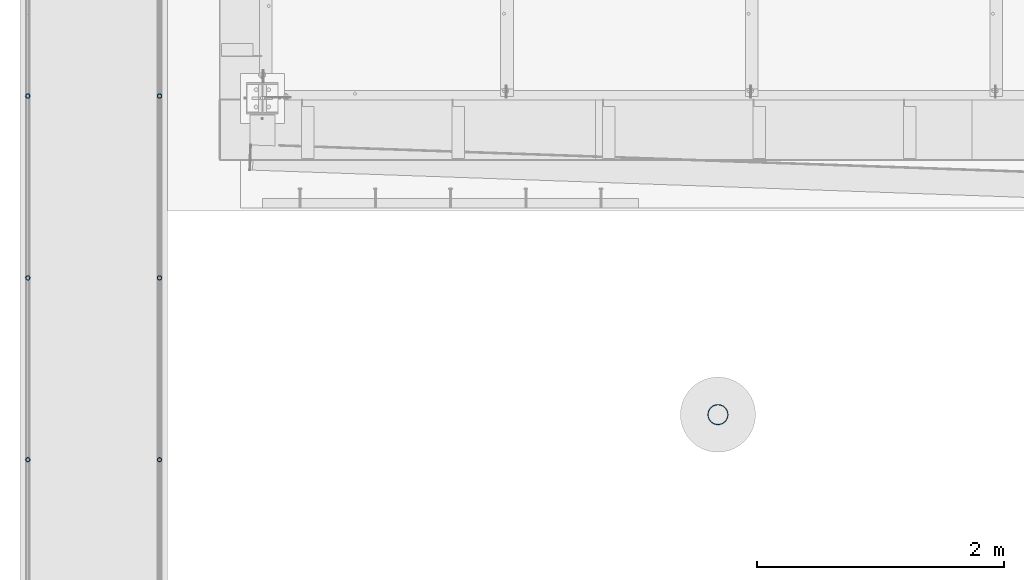
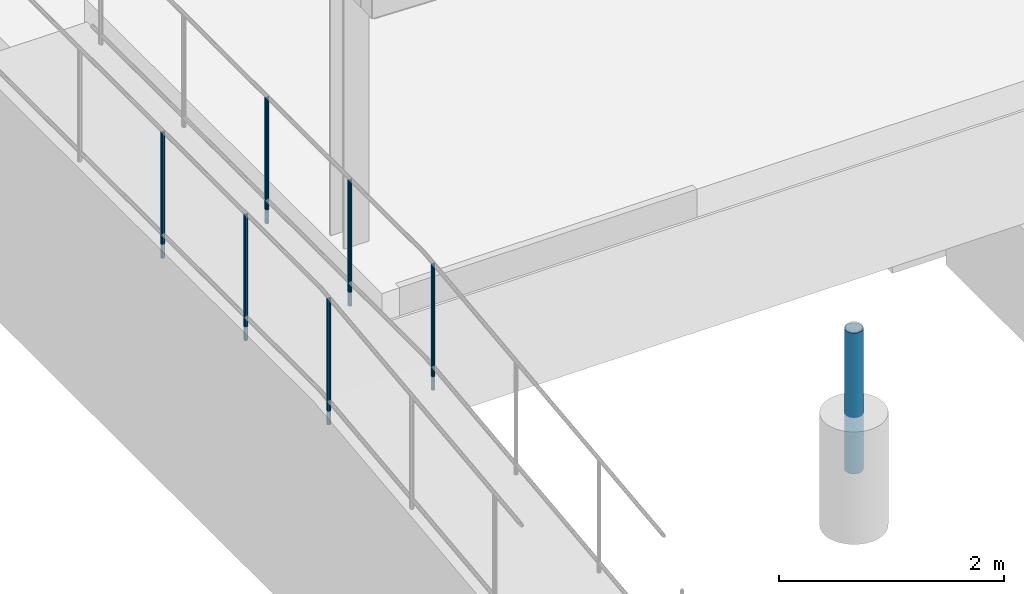
# One storey, part 884 of 1763: 7 columns, 3 elements without a shape of their own.
"""IFC2X3 building model written with IfcOpenShell, lengths in millimetres."""

import ifcopenshell
import ifcopenshell.guid

model = None  # the IFC model being written
_history = None  # IfcOwnerHistory: only IFC2X3 demands one
_inside = {}  # id of a spatial element -> (the spatial element, [elements in it])
_under = {}  # id of a project, library or spatial element -> (it, [spatial elements below it])
_declared = {}  # id of a project -> (the project, [libraries it declares])
_typed = {}  # id of a type object -> (the type object, [elements of that type])
_made_of = {}  # id of a material, layer set ... -> (it, [elements and type objects made of it])


def new_model(schema):
    """Start an empty IFC model of exactly this schema.

    Asked for "IFC4X3", IfcOpenShell would pick the latest addendum, in which some entities
    have other attributes; the version numbers below select the first issue.
    IFC2X3 requires an IfcOwnerHistory on every rooted entity: one is made here for all.
    """
    global model, _history
    if schema == "IFC4X3":
        model = ifcopenshell.file(schema_version=(4, 3, 0, 0))
    else:
        model = ifcopenshell.file(schema=schema)
    _inside.clear()
    _under.clear()
    _declared.clear()
    _typed.clear()
    _made_of.clear()
    _history = None
    if model.schema == "IFC2X3":
        org = make("IfcOrganization", Name="unknown")
        user = make(
            "IfcPersonAndOrganization",
            ThePerson=make("IfcPerson", FamilyName="unknown"),
            TheOrganization=org,
        )
        app = make(
            "IfcApplication",
            ApplicationDeveloper=org,
            Version="unknown",
            ApplicationFullName="unknown",
            ApplicationIdentifier="unknown",
        )
        _history = make(
            "IfcOwnerHistory",
            OwningUser=user,
            OwningApplication=app,
            ChangeAction="ADDED",
            CreationDate=0,
        )
    return model


def make(cls, **values):
    """One entity of the class cls with the attributes given. An attribute that is None is left unset."""
    return model.create_entity(
        cls, **{name: value for name, value in values.items() if value is not None}
    )


def rooted(cls, **values):
    """An entity with a GlobalId (a new one), such as an element, a storey or a relation."""
    return make(cls, GlobalId=ifcopenshell.guid.new(), OwnerHistory=_history, **values)


def si_unit(unit_type, name, prefix=None):
    """IfcSIUnit, for example si_unit("LENGTHUNIT", "METRE", prefix="MILLI")."""
    return make("IfcSIUnit", UnitType=unit_type, Prefix=prefix, Name=name)


def assignment(units):
    """IfcUnitAssignment: the units of a project."""
    return None if units is None else make("IfcUnitAssignment", Units=units)


def point(xyz):
    """IfcCartesianPoint."""
    return None if xyz is None else make("IfcCartesianPoint", Coordinates=xyz)


def direction(xyz):
    """IfcDirection."""
    return None if xyz is None else make("IfcDirection", DirectionRatios=xyz)


def frame(location, z_axis=None, x_axis=None):
    """IfcAxis2Placement3D, a coordinate frame: its origin and axes. An axis left out is left unset."""
    return make(
        "IfcAxis2Placement3D",
        Location=point(location),
        Axis=direction(z_axis),
        RefDirection=direction(x_axis),
    )


def origin_with_axes():
    """The frame at (0, 0, 0) with the z axis (0, 0, 1) and the x axis (1, 0, 0) written out."""
    return frame((0.0, 0.0, 0.0), z_axis=(0.0, 0.0, 1.0), x_axis=(1.0, 0.0, 0.0))


def place(relative_to, where):
    """IfcLocalPlacement: puts the frame where relative to a parent placement (None: the world)."""
    return make(
        "IfcLocalPlacement", PlacementRelTo=relative_to, RelativePlacement=where
    )


def context(
    kind, dimensions, precision=None, world=None, true_north=None, identifier=None
):
    """IfcGeometricRepresentationContext, for example the 3D "Model" context."""
    return make(
        "IfcGeometricRepresentationContext",
        ContextIdentifier=identifier,
        ContextType=kind,
        CoordinateSpaceDimension=dimensions,
        Precision=precision,
        WorldCoordinateSystem=world,
        TrueNorth=true_north,
    )


def subcontext(parent, identifier, kind, view, scale=None):
    """IfcGeometricRepresentationSubContext, for example "Body" below "Model"."""
    return make(
        "IfcGeometricRepresentationSubContext",
        ContextIdentifier=identifier,
        ContextType=kind,
        ParentContext=parent,
        TargetScale=scale,
        TargetView=view,
    )


def project(units=None, contexts=None):
    """IfcProject with its units and contexts."""
    return rooted(
        "IfcProject",
        Name="project",
        RepresentationContexts=contexts,
        UnitsInContext=assignment(units),
    )


def spatial(cls, under=None, at=None, **own):
    """A site, building, storey or space (cls), placed at a placement, below another one or the project."""
    s = rooted(cls, ObjectPlacement=at, **own)
    if under is not None:
        _under.setdefault(under.id(), (under, []))[1].append(s)
    return s


def faces_of(points, faces, orient=None, outer=None):
    """IfcFace entities. A face is a list of loops; a loop is a list of indices into points, from 0.

    orient and outer hold one flag for each loop. By default every Orientation is true, the
    first loop of a face is its IfcFaceOuterBound and the others are IfcFaceBound.
    """
    made = []
    for i, loops in enumerate(faces):
        bounds = []
        for j, loop in enumerate(loops):
            is_outer = j == 0 if outer is None else outer[i][j]
            bounds.append(
                make(
                    "IfcFaceOuterBound" if is_outer else "IfcFaceBound",
                    Bound=make("IfcPolyLoop", Polygon=[points[k] for k in loop]),
                    Orientation=True if orient is None else orient[i][j],
                )
            )
        made.append(make("IfcFace", Bounds=bounds))
    return made


def faceted_brep(points, faces, orient=None, outer=None, voids=None):
    """IfcFacetedBrep: a solid bounded by flat faces; with voids (closed shells), ...WithVoids."""
    shared = [point(p) for p in points]
    hull = make("IfcClosedShell", CfsFaces=faces_of(shared, faces, orient, outer))
    if voids is None:
        return make("IfcFacetedBrep", Outer=hull)
    return make(
        "IfcFacetedBrepWithVoids",
        Outer=hull,
        Voids=[
            make(cls, CfsFaces=faces_of(shared, fs, o, b)) for cls, fs, o, b in voids
        ],
    )


def shape(context_of_items, identifier, shape_type, items):
    """IfcShapeRepresentation: the items that make up one representation, for example the "Body"."""
    return make(
        "IfcShapeRepresentation",
        ContextOfItems=context_of_items,
        RepresentationIdentifier=identifier,
        RepresentationType=shape_type,
        Items=items,
    )


def material(Name=None, Category=None):
    """IfcMaterial."""
    return make("IfcMaterial", Name=Name, Category=Category)


def made_of(thing, what):
    """Note that an element or type object is made of a material, layer set ...; save() writes the relation."""
    if what is not None:
        _made_of.setdefault(what.id(), (what, []))[1].append(thing)
    return thing


def type_object(cls, material=None, **own):
    """A type object (cls), such as IfcWallType, which elements share."""
    return made_of(rooted(cls, **own), material)


def element(
    cls,
    number,
    at=None,
    inside=None,
    cuts=None,
    type_object=None,
    material=None,
    context=None,
    identifier="Body",
    shape_type=None,
    held_by="IfcProductDefinitionShape",
    body=None,
    shapes=None,
    **own,
):
    """One element of the class cls, such as IfcWall. Its Tag is "e" and its number.

    at: its placement. inside: the storey or other place that contains it. cuts: it is an
    opening in that element (IfcRelVoidsElement). A single representation is given by context,
    identifier, shape_type and body (its items); several are given by shapes. held_by: the class
    of the entity that holds the representations. save() writes the other relations.
    """
    e = rooted(cls, Tag="e%d" % number, ObjectPlacement=at, **own)
    if body is not None:
        shapes = [shape(context, identifier, shape_type, body)]
    if shapes is not None:
        e.Representation = make(held_by, Representations=shapes)
    if inside is not None:
        _inside.setdefault(inside.id(), (inside, []))[1].append(e)
    if cuts is not None:
        rooted(
            "IfcRelVoidsElement", RelatingBuildingElement=cuts, RelatedOpeningElement=e
        )
    if type_object is not None:
        _typed.setdefault(type_object.id(), (type_object, []))[1].append(e)
    return made_of(e, material)


def aggregate(whole, parts):
    """IfcRelAggregates: a whole, such as a stair, and the parts it consists of."""
    return rooted("IfcRelAggregates", RelatingObject=whole, RelatedObjects=parts)


def save(model, path):
    """Write the relations noted so far, then the file.

    IfcRelAggregates (storeys below a building ...), IfcRelContainedInSpatialStructure (elements
    in a storey), IfcRelDefinesByType, IfcRelAssociatesMaterial and IfcRelDeclares: one each for
    every whole, place, type object, material and project.
    """
    for whole, parts in _under.values():
        aggregate(whole, parts)
    for where, things in _inside.values():
        rooted(
            "IfcRelContainedInSpatialStructure",
            RelatedElements=things,
            RelatingStructure=where,
        )
    for kind, things in _typed.values():
        rooted("IfcRelDefinesByType", RelatedObjects=things, RelatingType=kind)
    for what, things in _made_of.values():
        rooted("IfcRelAssociatesMaterial", RelatedObjects=things, RelatingMaterial=what)
    for by, libraries in _declared.values():
        rooted("IfcRelDeclares", RelatingContext=by, RelatedDefinitions=libraries)
    model.write(path)


model = new_model("IFC2X3")

# Units and contexts
model_context = context("Model", 3, precision=1e-05, world=origin_with_axes())
body_context = subcontext(model_context, "Body", "Model", "MODEL_VIEW")
ifc_project = project(units=[si_unit("LENGTHUNIT", "METRE", prefix="MILLI"), si_unit("AREAUNIT", "SQUARE_METRE"), si_unit("VOLUMEUNIT", "CUBIC_METRE"), si_unit("MASSUNIT", "GRAM", prefix="KILO"), si_unit("TIMEUNIT", "SECOND"), si_unit("PLANEANGLEUNIT", "RADIAN"), si_unit("SOLIDANGLEUNIT", "STERADIAN"), si_unit("THERMODYNAMICTEMPERATUREUNIT", "DEGREE_CELSIUS"), si_unit("LUMINOUSINTENSITYUNIT", "LUMEN")], contexts=[model_context])

# Site, building, storey
site_placement = place(None, origin_with_axes())
site = spatial("IfcSite", under=ifc_project, at=site_placement, CompositionType="ELEMENT")
building_placement = place(site_placement, origin_with_axes())
building = spatial("IfcBuilding", under=site, at=building_placement, Name="Undefined", CompositionType="ELEMENT")
storey_placement = place(building_placement, origin_with_axes())
storey = spatial("IfcBuildingStorey", under=building, at=storey_placement, Name="Undefined", CompositionType="ELEMENT", Elevation=0.0)

# Assembly, columns
assembly_1_placement = place(storey_placement, origin_with_axes())
assembly_1 = element("IfcElementAssembly", 1, at=assembly_1_placement, inside=storey, Name="GUARDRAIL", AssemblyPlace="NOTDEFINED", PredefinedType="RIGID_FRAME")
ifc_material_1 = material(Name="STEEL/A513")
column_type_1 = type_object("IfcColumnType", PredefinedType="NOTDEFINED")
column_1_placement = place(assembly_1_placement, frame((-97200.6527017878, 9315.24317321462, 5777.83146284698), z_axis=(0.0, -1.0, 0.0), x_axis=(0.0, 0.0, 1.0)))
column_1 = element("IfcColumn", 2, at=column_1_placement, type_object=column_type_1, material=ifc_material_1, Name="POST TUBE", context=body_context, shape_type="Brep", body=[
    faceted_brep([(1355.1022096743, -9.52499999999418, 16.4977839408602), (1355.10221219201, -9.52499999999418, 9.99208795533559), (1354.46415725589, -7.14375000000291, 12.3733379553378), (1352.54999447178, 0.0, 14.2874999987689), (1352.54999262869, 0.0, 19.0499999987678), (1354.46415725589, 7.14375000000291, 12.3733379553378), (1355.10221219201, 9.52499999999418, 9.99208795533559), (1355.1022096743, 9.52499999999418, 16.4977839408602), (1371.59999999763, 19.0500000000029, -8.9130480773747e-11), (1362.07499631487, 16.4977839420899, 9.52499999875909), (1362.07497456074, 16.4977839420899, -9.52500000008877), (1357.95050358876, 12.3733379565674, 7.14374999991196), (1359.86467634067, 14.2875000000058, -8.9130480773747e-11), (1357.95052500572, 12.3733379565674, -7.1437500000884), (1355.1021913188, 9.52499999999418, -9.992087956658), (1355.10220107084, 9.52499999999418, -16.4977839421827), (1354.46414087382, 7.14375000000291, -12.3733379566584), (1352.54998169972, 0.0, -14.2875000000895), (1352.5499888387, 0.0, -19.0500000000884), (1355.1021913188, -9.52499999999418, -9.992087956658), (1355.10220107084, -9.52499999999418, -16.4977839421827), (1354.46414087382, -7.14375000000291, -12.3733379566584), (1371.59996028277, -19.0500000000029, -1.4915713109076e-10), (1362.07497456074, -16.4977839420899, -9.52500000008877), (1362.07499631487, -16.4977839420899, 9.52499999875909), (1357.95052500571, -12.3733379565674, -7.1437500000884), (1359.86467634067, -14.2875000000058, -8.9130480773747e-11), (1357.95050358875, -12.3733379565674, 7.14374999991196), (0.0, -16.4977839420899, -9.52500000000146), (0.0, -9.52499999999418, -16.4977839420935), (1.45519152283669e-11, 1.81898940354586e-12, -19.0499999999993), (0.0, 9.52499999999418, -16.4977839420935), (0.0, 16.4977839420899, -9.52500000000146), (0.0, 19.0500000000029, 0.0), (0.0, 16.4977839420899, 9.52500000000146), (0.0, 9.52499999999418, 16.4977839420935), (1.45519152283669e-11, 1.81898940354586e-12, 19.0499999999993), (0.0, -9.52499999999418, 16.4977839420935), (0.0, -16.4977839420899, 9.52500000000146), (0.0, -19.0500000000029, 0.0), (0.0, -12.3733379565674, -7.14374999999927), (0.0, -7.14375000000291, -12.373337956571), (0.0, 0.0, -14.2874999999985), (0.0, 7.14375000000291, -12.373337956571), (0.0, 12.3733379565674, -7.14374999999927), (0.0, 14.2875000000058, 0.0), (0.0, 12.3733379565674, 7.14374999999927), (0.0, 7.14375000000291, 12.373337956571), (0.0, 0.0, 14.2874999999985), (0.0, -7.14375000000291, 12.373337956571), (0.0, -12.3733379565674, 7.14374999999927), (0.0, -14.2875000000058, 0.0)], [[[0, 1, 2, 3, 4]], [[4, 3, 5, 6, 7]], [[8, 9, 10]], [[7, 6, 11, 12, 13, 14, 15, 10, 9]], [[16, 17, 18, 15, 14]], [[19, 20, 18, 17, 21]], [[22, 23, 24]], [[24, 23, 20, 19, 25, 26, 27, 1, 0]], [[28, 29, 20, 23]], [[29, 30, 18, 20]], [[30, 31, 15, 18]], [[31, 32, 10, 15]], [[32, 33, 8, 10]], [[33, 34, 9, 8]], [[34, 35, 7, 9]], [[35, 36, 4, 7]], [[36, 37, 0, 4]], [[37, 38, 24, 0]], [[38, 39, 22, 24]], [[39, 28, 23, 22]], [[38, 37, 36, 35, 34, 33, 32, 31, 30, 29, 28, 39], [40, 41, 42, 43, 44, 45, 46, 47, 48, 49, 50, 51]], [[40, 51, 26, 25]], [[21, 41, 40, 25, 19]], [[42, 41, 21, 17]], [[43, 42, 17, 16]], [[44, 43, 16, 14, 13]], [[45, 44, 13, 12]], [[46, 45, 12, 11]], [[5, 47, 46, 11, 6]], [[48, 47, 5, 3]], [[49, 48, 3, 2]], [[50, 49, 2, 1, 27]], [[51, 50, 27, 26]]]),
])
column_2_placement = place(assembly_1_placement, frame((-97200.6527017878, 7842.04317321462, 5777.83146284698), z_axis=(0.0, -1.0, 0.0), x_axis=(0.0, 0.0, 1.0)))
column_2 = element("IfcColumn", 3, at=column_2_placement, type_object=column_type_1, material=ifc_material_1, Name="POST TUBE", context=body_context, shape_type="Brep", body=[
    faceted_brep([(1355.1022096743, -9.52499999999418, 16.4977839408602), (1355.10221219201, -9.52499999999418, 9.99208795533559), (1354.46415725589, -7.14375000000291, 12.3733379553378), (1352.54999447178, 0.0, 14.2874999987689), (1352.54999262869, 0.0, 19.0499999987678), (1354.46415725589, 7.14375000000291, 12.3733379553378), (1355.10221219201, 9.52499999999418, 9.99208795533559), (1355.1022096743, 9.52499999999418, 16.4977839408602), (1371.59999999763, 19.0500000000029, -8.9130480773747e-11), (1362.07499631487, 16.4977839420899, 9.52499999875909), (1362.07497456074, 16.4977839420899, -9.52500000008877), (1357.95050358876, 12.3733379565674, 7.14374999991196), (1359.86467634067, 14.2875000000058, -8.9130480773747e-11), (1357.95052500572, 12.3733379565674, -7.1437500000884), (1355.1021913188, 9.52499999999418, -9.992087956658), (1355.10220107084, 9.52499999999418, -16.4977839421827), (1354.46414087382, 7.14375000000291, -12.3733379566584), (1352.54998169972, 0.0, -14.2875000000895), (1352.5499888387, 0.0, -19.0500000000884), (1355.1021913188, -9.52499999999418, -9.992087956658), (1355.10220107084, -9.52499999999418, -16.4977839421827), (1354.46414087382, -7.14375000000291, -12.3733379566584), (1371.59996028277, -19.0500000000029, -1.4915713109076e-10), (1362.07497456074, -16.4977839420899, -9.52500000008877), (1362.07499631487, -16.4977839420899, 9.52499999875909), (1357.95052500571, -12.3733379565674, -7.1437500000884), (1359.86467634067, -14.2875000000058, -8.9130480773747e-11), (1357.95050358875, -12.3733379565674, 7.14374999991196), (0.0, -16.4977839420899, -9.52500000000146), (0.0, -9.52499999999418, -16.4977839420935), (1.45519152283669e-11, 1.81898940354586e-12, -19.0499999999993), (0.0, 9.52499999999418, -16.4977839420935), (0.0, 16.4977839420899, -9.52500000000146), (0.0, 19.0500000000029, 0.0), (0.0, 16.4977839420899, 9.52500000000146), (0.0, 9.52499999999418, 16.4977839420935), (1.45519152283669e-11, 1.81898940354586e-12, 19.0499999999993), (0.0, -9.52499999999418, 16.4977839420935), (0.0, -16.4977839420899, 9.52500000000146), (0.0, -19.0500000000029, 0.0), (0.0, -12.3733379565674, -7.14374999999927), (0.0, -7.14375000000291, -12.373337956571), (0.0, 0.0, -14.2874999999985), (0.0, 7.14375000000291, -12.373337956571), (0.0, 12.3733379565674, -7.14374999999927), (0.0, 14.2875000000058, 0.0), (0.0, 12.3733379565674, 7.14374999999927), (0.0, 7.14375000000291, 12.373337956571), (0.0, 0.0, 14.2874999999985), (0.0, -7.14375000000291, 12.373337956571), (0.0, -12.3733379565674, 7.14374999999927), (0.0, -14.2875000000058, 0.0)], [[[0, 1, 2, 3, 4]], [[4, 3, 5, 6, 7]], [[8, 9, 10]], [[7, 6, 11, 12, 13, 14, 15, 10, 9]], [[16, 17, 18, 15, 14]], [[19, 20, 18, 17, 21]], [[22, 23, 24]], [[24, 23, 20, 19, 25, 26, 27, 1, 0]], [[28, 29, 20, 23]], [[29, 30, 18, 20]], [[30, 31, 15, 18]], [[31, 32, 10, 15]], [[32, 33, 8, 10]], [[33, 34, 9, 8]], [[34, 35, 7, 9]], [[35, 36, 4, 7]], [[36, 37, 0, 4]], [[37, 38, 24, 0]], [[38, 39, 22, 24]], [[39, 28, 23, 22]], [[38, 37, 36, 35, 34, 33, 32, 31, 30, 29, 28, 39], [40, 41, 42, 43, 44, 45, 46, 47, 48, 49, 50, 51]], [[40, 51, 26, 25]], [[21, 41, 40, 25, 19]], [[42, 41, 21, 17]], [[43, 42, 17, 16]], [[44, 43, 16, 14, 13]], [[45, 44, 13, 12]], [[46, 45, 12, 11]], [[5, 47, 46, 11, 6]], [[48, 47, 5, 3]], [[49, 48, 3, 2]], [[50, 49, 2, 1, 27]], [[51, 50, 27, 26]]]),
])
column_3_placement = place(assembly_1_placement, frame((-97200.6527017878, 6368.8373249323, 5760.41674084824), z_axis=(0.0, -0.999999999989044, 4.68099999989136e-06), x_axis=(0.0, 4.68100000009712e-06, 0.999999999989044)))
column_3 = element("IfcColumn", 4, at=column_3_placement, type_object=column_type_1, material=ifc_material_1, Name="POST TUBE", context=body_context, shape_type="Brep", body=[
    faceted_brep([(1371.60074802696, 19.0500000000029, -4.95674612466246e-10), (1360.92004811796, 16.4977839420899, 9.52499999950942), (1363.10730659688, 16.4977839420899, -9.52500000049167), (1352.93217122176, -7.14375000000291, 12.3733379560817), (1350.78565560214, 0.0, 14.2874999995129), (1350.23884098241, 0.0, 19.0499999995127), (1353.10086180857, -9.52499999999418, 16.4977839416069), (1353.84782447028, -9.52499999999418, 9.99208795608138), (1353.84782447028, 9.52499999999418, 9.99208795608138), (1353.10086180857, 9.52499999999418, 16.4977839416069), (1352.93217122176, 7.14375000000291, 12.3733379560817), (1357.04191241844, 12.3733379565674, 7.14374999951087), (1359.78887216401, 14.2875000000058, -4.91127138957381e-10), (1358.68235627764, 12.3733379565674, -7.14375000048949), (1356.14234196164, 9.52499999999418, -9.99208795705908), (1356.88930462336, 9.52499999999418, -16.4977839425837), (1355.77350333285, 7.14375000000291, -12.3733379570585), (1354.06654332053, 0.0, -14.2875000004888), (1354.61335794026, 0.0, -19.0500000004886), (1355.77350333285, -7.14375000000291, -12.3733379570585), (1356.14234196164, -9.52499999999418, -9.99208795705908), (1356.88930462336, -9.52499999999418, -16.4977839425837), (1371.6012486538, -19.0500000000029, 5.74798359593842e-05), (1363.10730659688, -16.4977839420899, -9.52500000049167), (1360.92004811796, -16.4977839420899, 9.52499999950942), (1358.68235627763, -12.3733379565674, -7.14375000048949), (1359.788872164, -14.2875000000058, -4.91127138957381e-10), (1357.04191241844, -12.3733379565674, 7.14374999951087), (0.0, -16.4977839420899, -9.52500000000146), (0.0, -9.52499999999418, -16.4977839420935), (1.45519152283669e-11, 1.81898940354586e-12, -19.0499999999993), (0.0, 9.52499999999418, -16.4977839420935), (0.0, 16.4977839420899, -9.52500000000146), (0.0, 19.0500000000029, 0.0), (0.0, 16.4977839420899, 9.52500000000146), (0.0, 9.52499999999418, 16.4977839420935), (1.45519152283669e-11, 1.81898940354586e-12, 19.0499999999993), (0.0, -9.52499999999418, 16.4977839420935), (0.0, -16.4977839420899, 9.52500000000146), (0.0, -19.0500000000029, 0.0), (0.0, -12.3733379565674, -7.14374999999927), (0.0, -7.14375000000291, -12.373337956571), (0.0, 0.0, -14.2874999999985), (0.0, 7.14375000000291, -12.373337956571), (0.0, 12.3733379565674, -7.14374999999927), (0.0, 14.2875000000058, 0.0), (0.0, 12.3733379565674, 7.14374999999927), (0.0, 7.14375000000291, 12.373337956571), (0.0, 0.0, 14.2874999999985), (0.0, -7.14375000000291, 12.373337956571), (0.0, -12.3733379565674, 7.14374999999927), (0.0, -14.2875000000058, 0.0)], [[[0, 1, 2]], [[3, 4, 5, 6, 7]], [[8, 9, 5, 4, 10]], [[2, 1, 9, 8, 11, 12, 13, 14, 15]], [[15, 14, 16, 17, 18]], [[18, 17, 19, 20, 21]], [[22, 23, 24]], [[21, 20, 25, 26, 27, 7, 6, 24, 23]], [[28, 29, 21, 23]], [[29, 30, 18, 21]], [[30, 31, 15, 18]], [[31, 32, 2, 15]], [[32, 33, 0, 2]], [[33, 34, 1, 0]], [[34, 35, 9, 1]], [[35, 36, 5, 9]], [[36, 37, 6, 5]], [[37, 38, 24, 6]], [[38, 39, 22, 24]], [[39, 28, 23, 22]], [[38, 37, 36, 35, 34, 33, 32, 31, 30, 29, 28, 39], [40, 41, 42, 43, 44, 45, 46, 47, 48, 49, 50, 51]], [[40, 51, 26, 25]], [[19, 41, 40, 25, 20]], [[42, 41, 19, 17]], [[43, 42, 17, 16]], [[44, 43, 16, 14, 13]], [[45, 44, 13, 12]], [[46, 45, 12, 11]], [[10, 47, 46, 11, 8]], [[48, 47, 10, 4]], [[49, 48, 4, 3]], [[50, 49, 3, 7, 27]], [[51, 50, 27, 26]]]),
])
aggregate(assembly_1, [column_1, column_2, column_3])

assembly_2_placement = place(storey_placement, origin_with_axes())
assembly_2 = element("IfcElementAssembly", 5, at=assembly_2_placement, inside=storey, Name="GUARDRAIL", AssemblyPlace="NOTDEFINED", PredefinedType="RIGID_FRAME")
column_4_placement = place(assembly_2_placement, frame((-96133.8527017878, 9315.24317321462, 5777.83146284698), z_axis=(0.0, -1.0, 0.0), x_axis=(0.0, 0.0, 1.0)))
column_4 = element("IfcColumn", 6, at=column_4_placement, type_object=column_type_1, material=ifc_material_1, Name="POST TUBE", context=body_context, shape_type="Brep", body=[
    faceted_brep([(1355.1022096743, -9.52499999999418, 16.4977839408602), (1355.10221219201, -9.52499999999418, 9.99208795533559), (1354.46415725589, -7.14375000000291, 12.3733379553378), (1352.54999447178, 0.0, 14.2874999987689), (1352.54999262869, 0.0, 19.0499999987678), (1354.46415725589, 7.14375000000291, 12.3733379553378), (1355.10221219201, 9.52499999999418, 9.99208795533559), (1355.1022096743, 9.52499999999418, 16.4977839408602), (1371.59999999763, 19.0500000000029, -8.9130480773747e-11), (1362.07499631487, 16.4977839420899, 9.52499999875909), (1362.07497456074, 16.4977839420899, -9.52500000008877), (1357.95050358876, 12.3733379565674, 7.14374999991196), (1359.86467634067, 14.2875000000058, -8.9130480773747e-11), (1357.95052500572, 12.3733379565674, -7.1437500000884), (1355.1021913188, 9.52499999999418, -9.992087956658), (1355.10220107084, 9.52499999999418, -16.4977839421827), (1354.46414087382, 7.14375000000291, -12.3733379566584), (1352.54998169972, 0.0, -14.2875000000895), (1352.5499888387, 0.0, -19.0500000000884), (1355.1021913188, -9.52499999999418, -9.992087956658), (1355.10220107084, -9.52499999999418, -16.4977839421827), (1354.46414087382, -7.14375000000291, -12.3733379566584), (1371.59996028277, -19.0500000000029, -1.4915713109076e-10), (1362.07497456074, -16.4977839420899, -9.52500000008877), (1362.07499631487, -16.4977839420899, 9.52499999875909), (1357.95052500571, -12.3733379565674, -7.1437500000884), (1359.86467634067, -14.2875000000058, -8.9130480773747e-11), (1357.95050358875, -12.3733379565674, 7.14374999991196), (0.0, -16.4977839420899, -9.52500000000146), (0.0, -9.52499999999418, -16.4977839420935), (1.45519152283669e-11, 1.81898940354586e-12, -19.0499999999993), (0.0, 9.52499999999418, -16.4977839420935), (0.0, 16.4977839420899, -9.52500000000146), (0.0, 19.0500000000029, 0.0), (0.0, 16.4977839420899, 9.52500000000146), (0.0, 9.52499999999418, 16.4977839420935), (1.45519152283669e-11, 1.81898940354586e-12, 19.0499999999993), (0.0, -9.52499999999418, 16.4977839420935), (0.0, -16.4977839420899, 9.52500000000146), (0.0, -19.0500000000029, 0.0), (0.0, -12.3733379565674, -7.14374999999927), (0.0, -7.14375000000291, -12.373337956571), (0.0, 0.0, -14.2874999999985), (0.0, 7.14375000000291, -12.373337956571), (0.0, 12.3733379565674, -7.14374999999927), (0.0, 14.2875000000058, 0.0), (0.0, 12.3733379565674, 7.14374999999927), (0.0, 7.14375000000291, 12.373337956571), (0.0, 0.0, 14.2874999999985), (0.0, -7.14375000000291, 12.373337956571), (0.0, -12.3733379565674, 7.14374999999927), (0.0, -14.2875000000058, 0.0)], [[[0, 1, 2, 3, 4]], [[4, 3, 5, 6, 7]], [[8, 9, 10]], [[7, 6, 11, 12, 13, 14, 15, 10, 9]], [[16, 17, 18, 15, 14]], [[19, 20, 18, 17, 21]], [[22, 23, 24]], [[24, 23, 20, 19, 25, 26, 27, 1, 0]], [[28, 29, 20, 23]], [[29, 30, 18, 20]], [[30, 31, 15, 18]], [[31, 32, 10, 15]], [[32, 33, 8, 10]], [[33, 34, 9, 8]], [[34, 35, 7, 9]], [[35, 36, 4, 7]], [[36, 37, 0, 4]], [[37, 38, 24, 0]], [[38, 39, 22, 24]], [[39, 28, 23, 22]], [[38, 37, 36, 35, 34, 33, 32, 31, 30, 29, 28, 39], [40, 41, 42, 43, 44, 45, 46, 47, 48, 49, 50, 51]], [[40, 51, 26, 25]], [[21, 41, 40, 25, 19]], [[42, 41, 21, 17]], [[43, 42, 17, 16]], [[44, 43, 16, 14, 13]], [[45, 44, 13, 12]], [[46, 45, 12, 11]], [[5, 47, 46, 11, 6]], [[48, 47, 5, 3]], [[49, 48, 3, 2]], [[50, 49, 2, 1, 27]], [[51, 50, 27, 26]]]),
])
column_5_placement = place(assembly_2_placement, frame((-96133.8527017878, 7842.04317321462, 5777.83146284698), z_axis=(0.0, -1.0, 0.0), x_axis=(0.0, 0.0, 1.0)))
column_5 = element("IfcColumn", 7, at=column_5_placement, type_object=column_type_1, material=ifc_material_1, Name="POST TUBE", context=body_context, shape_type="Brep", body=[
    faceted_brep([(1355.1022096743, -9.52499999999418, 16.4977839408602), (1355.10221219201, -9.52499999999418, 9.99208795533559), (1354.46415725589, -7.14375000000291, 12.3733379553378), (1352.54999447178, 0.0, 14.2874999987689), (1352.54999262869, 0.0, 19.0499999987678), (1354.46415725589, 7.14375000000291, 12.3733379553378), (1355.10221219201, 9.52499999999418, 9.99208795533559), (1355.1022096743, 9.52499999999418, 16.4977839408602), (1371.59999999763, 19.0500000000029, -8.9130480773747e-11), (1362.07499631487, 16.4977839420899, 9.52499999875909), (1362.07497456074, 16.4977839420899, -9.52500000008877), (1357.95050358876, 12.3733379565674, 7.14374999991196), (1359.86467634067, 14.2875000000058, -8.9130480773747e-11), (1357.95052500572, 12.3733379565674, -7.1437500000884), (1355.1021913188, 9.52499999999418, -9.992087956658), (1355.10220107084, 9.52499999999418, -16.4977839421827), (1354.46414087382, 7.14375000000291, -12.3733379566584), (1352.54998169972, 0.0, -14.2875000000895), (1352.5499888387, 0.0, -19.0500000000884), (1355.1021913188, -9.52499999999418, -9.992087956658), (1355.10220107084, -9.52499999999418, -16.4977839421827), (1354.46414087382, -7.14375000000291, -12.3733379566584), (1371.59996028277, -19.0500000000029, -1.4915713109076e-10), (1362.07497456074, -16.4977839420899, -9.52500000008877), (1362.07499631487, -16.4977839420899, 9.52499999875909), (1357.95052500571, -12.3733379565674, -7.1437500000884), (1359.86467634067, -14.2875000000058, -8.9130480773747e-11), (1357.95050358875, -12.3733379565674, 7.14374999991196), (0.0, -16.4977839420899, -9.52500000000146), (0.0, -9.52499999999418, -16.4977839420935), (1.45519152283669e-11, 1.81898940354586e-12, -19.0499999999993), (0.0, 9.52499999999418, -16.4977839420935), (0.0, 16.4977839420899, -9.52500000000146), (0.0, 19.0500000000029, 0.0), (0.0, 16.4977839420899, 9.52500000000146), (0.0, 9.52499999999418, 16.4977839420935), (1.45519152283669e-11, 1.81898940354586e-12, 19.0499999999993), (0.0, -9.52499999999418, 16.4977839420935), (0.0, -16.4977839420899, 9.52500000000146), (0.0, -19.0500000000029, 0.0), (0.0, -12.3733379565674, -7.14374999999927), (0.0, -7.14375000000291, -12.373337956571), (0.0, 0.0, -14.2874999999985), (0.0, 7.14375000000291, -12.373337956571), (0.0, 12.3733379565674, -7.14374999999927), (0.0, 14.2875000000058, 0.0), (0.0, 12.3733379565674, 7.14374999999927), (0.0, 7.14375000000291, 12.373337956571), (0.0, 0.0, 14.2874999999985), (0.0, -7.14375000000291, 12.373337956571), (0.0, -12.3733379565674, 7.14374999999927), (0.0, -14.2875000000058, 0.0)], [[[0, 1, 2, 3, 4]], [[4, 3, 5, 6, 7]], [[8, 9, 10]], [[7, 6, 11, 12, 13, 14, 15, 10, 9]], [[16, 17, 18, 15, 14]], [[19, 20, 18, 17, 21]], [[22, 23, 24]], [[24, 23, 20, 19, 25, 26, 27, 1, 0]], [[28, 29, 20, 23]], [[29, 30, 18, 20]], [[30, 31, 15, 18]], [[31, 32, 10, 15]], [[32, 33, 8, 10]], [[33, 34, 9, 8]], [[34, 35, 7, 9]], [[35, 36, 4, 7]], [[36, 37, 0, 4]], [[37, 38, 24, 0]], [[38, 39, 22, 24]], [[39, 28, 23, 22]], [[38, 37, 36, 35, 34, 33, 32, 31, 30, 29, 28, 39], [40, 41, 42, 43, 44, 45, 46, 47, 48, 49, 50, 51]], [[40, 51, 26, 25]], [[21, 41, 40, 25, 19]], [[42, 41, 21, 17]], [[43, 42, 17, 16]], [[44, 43, 16, 14, 13]], [[45, 44, 13, 12]], [[46, 45, 12, 11]], [[5, 47, 46, 11, 6]], [[48, 47, 5, 3]], [[49, 48, 3, 2]], [[50, 49, 2, 1, 27]], [[51, 50, 27, 26]]]),
])
column_6_placement = place(assembly_2_placement, frame((-96133.8527017878, 6368.8373249323, 5760.41674084824), z_axis=(0.0, -0.999999999989044, 4.68099999989136e-06), x_axis=(0.0, 4.68100000009712e-06, 0.999999999989044)))
column_6 = element("IfcColumn", 8, at=column_6_placement, type_object=column_type_1, material=ifc_material_1, Name="POST TUBE", context=body_context, shape_type="Brep", body=[
    faceted_brep([(1371.60074802696, 19.0500000000029, -4.95674612466246e-10), (1360.92004811796, 16.4977839420899, 9.52499999950942), (1363.10730659688, 16.4977839420899, -9.52500000049167), (1352.93217122176, -7.14375000000291, 12.3733379560817), (1350.78565560214, 0.0, 14.2874999995129), (1350.23884098241, 0.0, 19.0499999995127), (1353.10086180857, -9.52499999999418, 16.4977839416069), (1353.84782447028, -9.52499999999418, 9.99208795608138), (1353.84782447028, 9.52499999999418, 9.99208795608138), (1353.10086180857, 9.52499999999418, 16.4977839416069), (1352.93217122176, 7.14375000000291, 12.3733379560817), (1357.04191241844, 12.3733379565674, 7.14374999951087), (1359.78887216401, 14.2875000000058, -4.91127138957381e-10), (1358.68235627764, 12.3733379565674, -7.14375000048949), (1356.14234196164, 9.52499999999418, -9.99208795705908), (1356.88930462336, 9.52499999999418, -16.4977839425837), (1355.77350333285, 7.14375000000291, -12.3733379570585), (1354.06654332053, 0.0, -14.2875000004888), (1354.61335794026, 0.0, -19.0500000004886), (1355.77350333285, -7.14375000000291, -12.3733379570585), (1356.14234196164, -9.52499999999418, -9.99208795705908), (1356.88930462336, -9.52499999999418, -16.4977839425837), (1371.6012486538, -19.0500000000029, 5.74798359593842e-05), (1363.10730659688, -16.4977839420899, -9.52500000049167), (1360.92004811796, -16.4977839420899, 9.52499999950942), (1358.68235627763, -12.3733379565674, -7.14375000048949), (1359.788872164, -14.2875000000058, -4.91127138957381e-10), (1357.04191241844, -12.3733379565674, 7.14374999951087), (0.0, -16.4977839420899, -9.52500000000146), (0.0, -9.52499999999418, -16.4977839420935), (1.45519152283669e-11, 1.81898940354586e-12, -19.0499999999993), (0.0, 9.52499999999418, -16.4977839420935), (0.0, 16.4977839420899, -9.52500000000146), (0.0, 19.0500000000029, 0.0), (0.0, 16.4977839420899, 9.52500000000146), (0.0, 9.52499999999418, 16.4977839420935), (1.45519152283669e-11, 1.81898940354586e-12, 19.0499999999993), (0.0, -9.52499999999418, 16.4977839420935), (0.0, -16.4977839420899, 9.52500000000146), (0.0, -19.0500000000029, 0.0), (0.0, -12.3733379565674, -7.14374999999927), (0.0, -7.14375000000291, -12.373337956571), (0.0, 0.0, -14.2874999999985), (0.0, 7.14375000000291, -12.373337956571), (0.0, 12.3733379565674, -7.14374999999927), (0.0, 14.2875000000058, 0.0), (0.0, 12.3733379565674, 7.14374999999927), (0.0, 7.14375000000291, 12.373337956571), (0.0, 0.0, 14.2874999999985), (0.0, -7.14375000000291, 12.373337956571), (0.0, -12.3733379565674, 7.14374999999927), (0.0, -14.2875000000058, 0.0)], [[[0, 1, 2]], [[3, 4, 5, 6, 7]], [[8, 9, 5, 4, 10]], [[2, 1, 9, 8, 11, 12, 13, 14, 15]], [[15, 14, 16, 17, 18]], [[18, 17, 19, 20, 21]], [[22, 23, 24]], [[21, 20, 25, 26, 27, 7, 6, 24, 23]], [[28, 29, 21, 23]], [[29, 30, 18, 21]], [[30, 31, 15, 18]], [[31, 32, 2, 15]], [[32, 33, 0, 2]], [[33, 34, 1, 0]], [[34, 35, 9, 1]], [[35, 36, 5, 9]], [[36, 37, 6, 5]], [[37, 38, 24, 6]], [[38, 39, 22, 24]], [[39, 28, 23, 22]], [[38, 37, 36, 35, 34, 33, 32, 31, 30, 29, 28, 39], [40, 41, 42, 43, 44, 45, 46, 47, 48, 49, 50, 51]], [[40, 51, 26, 25]], [[19, 41, 40, 25, 20]], [[42, 41, 19, 17]], [[43, 42, 17, 16]], [[44, 43, 16, 14, 13]], [[45, 44, 13, 12]], [[46, 45, 12, 11]], [[10, 47, 46, 11, 8]], [[48, 47, 10, 4]], [[49, 48, 4, 3]], [[50, 49, 3, 7, 27]], [[51, 50, 27, 26]]]),
])
aggregate(assembly_2, [column_4, column_5, column_6])

# Assembly, column
assembly_3_placement = place(storey_placement, origin_with_axes())
assembly_3 = element("IfcElementAssembly", 9, at=assembly_3_placement, inside=storey, Name="COLUMN", AssemblyPlace="NOTDEFINED", PredefinedType="RIGID_FRAME")
ifc_material_2 = material()
column_type_2 = type_object("IfcColumnType", Name="PIPE6STD", PredefinedType="NOTDEFINED")
column_7_placement = place(assembly_3_placement, frame((-91609.8972391413, 6734.09965622575, 3098.8), z_axis=(-1.0, 0.0, 0.0), x_axis=(0.0, 0.0, 1.0)))
column_7 = element("IfcColumn", 10, at=column_7_placement, type_object=column_type_2, material=ifc_material_2, Name="COLUMN", ObjectType="PIPE6STD", context=body_context, shape_type="Brep", body=[
    faceted_brep([(0.0, -77.0254999999997, 0.0), (0.0, -74.4009197328287, 19.9356663585495), (1524.0, -74.4009197328287, 19.9356663585495), (1524.0, -77.0254999999997, 0.0), (0.0, -66.7060397391979, 38.5127499999944), (1524.0, -66.7060397391979, 38.5127499999944), (0.0, -54.4652533742847, 54.4652533742774), (1524.0, -54.4652533742847, 54.4652533742774), (0.0, -38.5127499999999, 66.7060397392052), (1524.0, -38.5127499999999, 66.7060397392052), (0.0, -19.935666358544, 74.4009197328269), (1524.0, -19.935666358544, 74.4009197328269), (0.0, 0.0, 77.0255000000034), (1524.0, 0.0, 77.0255000000034), (0.0, 19.935666358544, 74.4009197328269), (1524.0, 19.935666358544, 74.4009197328269), (0.0, 38.5127499999999, 66.7060397392052), (1524.0, 38.5127499999999, 66.7060397392052), (0.0, 54.4652533742847, 54.4652533742774), (1524.0, 54.4652533742847, 54.4652533742774), (0.0, 66.7060397391979, 38.5127499999944), (1524.0, 66.7060397391979, 38.5127499999944), (0.0, 74.4009197328287, 19.9356663585495), (1524.0, 74.4009197328287, 19.9356663585495), (0.0, 77.0254999999997, 0.0), (1524.0, 77.0254999999997, 0.0), (0.0, 74.4009197328287, -19.9356663585495), (1524.0, 74.4009197328287, -19.9356663585495), (0.0, 66.7060397391979, -38.5127499999944), (1524.0, 66.7060397391979, -38.5127499999944), (0.0, 54.4652533742847, -54.4652533742774), (1524.0, 54.4652533742847, -54.4652533742774), (0.0, 38.5127499999999, -66.7060397392052), (1524.0, 38.5127499999999, -66.7060397392052), (0.0, 19.935666358544, -74.4009197328269), (1524.0, 19.935666358544, -74.4009197328269), (0.0, 0.0, -77.0255000000034), (1524.0, 0.0, -77.0255000000034), (0.0, -19.935666358544, -74.4009197328269), (1524.0, -19.935666358544, -74.4009197328269), (0.0, -38.5127499999999, -66.7060397392052), (1524.0, -38.5127499999999, -66.7060397392052), (0.0, -54.4652533742847, -54.4652533742774), (1524.0, -54.4652533742847, -54.4652533742774), (0.0, -66.7060397391979, -38.5127499999944), (1524.0, -66.7060397391979, -38.5127499999944), (0.0, -74.4009197328287, -19.9356663585495), (1524.0, -74.4009197328287, -19.9356663585495), (0.0, -84.1374999999998, 0.0), (0.0, -81.2705842093965, -21.7763874073135), (1524.0, -81.2705842093965, -21.7763874073135), (1524.0, -84.1374999999998, 0.0), (0.0, -72.865212410913, -42.0687500000058), (1524.0, -72.865212410913, -42.0687500000058), (0.0, -59.494196802083, -59.4941968020867), (1524.0, -59.494196802083, -59.4941968020867), (0.0, -42.0687500000004, -72.8652124109067), (1524.0, -42.0687500000004, -72.8652124109067), (0.0, -21.7763874073135, -81.2705842094001), (1524.0, -21.7763874073135, -81.2705842094001), (0.0, 0.0, -84.1374999999971), (1524.0, 0.0, -84.1374999999971), (0.0, 21.7763874073135, -81.2705842094001), (1524.0, 21.7763874073135, -81.2705842094001), (0.0, 42.0687500000004, -72.8652124109067), (1524.0, 42.0687500000004, -72.8652124109067), (0.0, 59.494196802083, -59.4941968020867), (1524.0, 59.494196802083, -59.4941968020867), (0.0, 72.865212410913, -42.0687500000058), (1524.0, 72.865212410913, -42.0687500000058), (0.0, 81.2705842093965, -21.7763874073135), (1524.0, 81.2705842093965, -21.7763874073135), (0.0, 84.1374999999998, 0.0), (1524.0, 84.1374999999998, 0.0), (0.0, 81.2705842093965, 21.7763874073135), (1524.0, 81.2705842093965, 21.7763874073135), (0.0, 72.865212410913, 42.0687500000058), (1524.0, 72.865212410913, 42.0687500000058), (0.0, 59.494196802083, 59.4941968020867), (1524.0, 59.494196802083, 59.4941968020867), (0.0, 42.0687500000004, 72.8652124109067), (1524.0, 42.0687500000004, 72.8652124109067), (0.0, 21.7763874073135, 81.2705842094001), (1524.0, 21.7763874073135, 81.2705842094001), (0.0, 0.0, 84.1374999999971), (1524.0, 0.0, 84.1374999999971), (0.0, -21.7763874073135, 81.2705842094001), (1524.0, -21.7763874073135, 81.2705842094001), (0.0, -42.0687500000004, 72.8652124109067), (1524.0, -42.0687500000004, 72.8652124109067), (0.0, -59.494196802083, 59.4941968020867), (1524.0, -59.494196802083, 59.4941968020867), (0.0, -72.865212410913, 42.0687500000058), (1524.0, -72.865212410913, 42.0687500000058), (0.0, -81.2705842093965, 21.7763874073135), (1524.0, -81.2705842093965, 21.7763874073135)], [[[0, 1, 2, 3]], [[1, 4, 5, 2]], [[4, 6, 7, 5]], [[6, 8, 9, 7]], [[8, 10, 11, 9]], [[10, 12, 13, 11]], [[12, 14, 15, 13]], [[14, 16, 17, 15]], [[16, 18, 19, 17]], [[18, 20, 21, 19]], [[20, 22, 23, 21]], [[22, 24, 25, 23]], [[24, 26, 27, 25]], [[26, 28, 29, 27]], [[28, 30, 31, 29]], [[30, 32, 33, 31]], [[32, 34, 35, 33]], [[34, 36, 37, 35]], [[36, 38, 39, 37]], [[38, 40, 41, 39]], [[40, 42, 43, 41]], [[42, 44, 45, 43]], [[44, 46, 47, 45]], [[46, 0, 3, 47]], [[48, 49, 50, 51]], [[49, 52, 53, 50]], [[52, 54, 55, 53]], [[54, 56, 57, 55]], [[56, 58, 59, 57]], [[58, 60, 61, 59]], [[60, 62, 63, 61]], [[62, 64, 65, 63]], [[64, 66, 67, 65]], [[66, 68, 69, 67]], [[68, 70, 71, 69]], [[70, 72, 73, 71]], [[72, 74, 75, 73]], [[74, 76, 77, 75]], [[76, 78, 79, 77]], [[78, 80, 81, 79]], [[80, 82, 83, 81]], [[82, 84, 85, 83]], [[84, 86, 87, 85]], [[86, 88, 89, 87]], [[88, 90, 91, 89]], [[90, 92, 93, 91]], [[92, 94, 95, 93]], [[94, 48, 51, 95]], [[53, 55, 57, 59, 61, 63, 65, 67, 69, 71, 73, 75, 77, 79, 81, 83, 85, 87, 89, 91, 93, 95, 51, 50], [5, 7, 9, 11, 13, 15, 17, 19, 21, 23, 25, 27, 29, 31, 33, 35, 37, 39, 41, 43, 45, 47, 3, 2]], [[94, 92, 90, 88, 86, 84, 82, 80, 78, 76, 74, 72, 70, 68, 66, 64, 62, 60, 58, 56, 54, 52, 49, 48], [46, 44, 42, 40, 38, 36, 34, 32, 30, 28, 26, 24, 22, 20, 18, 16, 14, 12, 10, 8, 6, 4, 1, 0]]]),
])
aggregate(assembly_3, [column_7])

save(model, "model.ifc")
